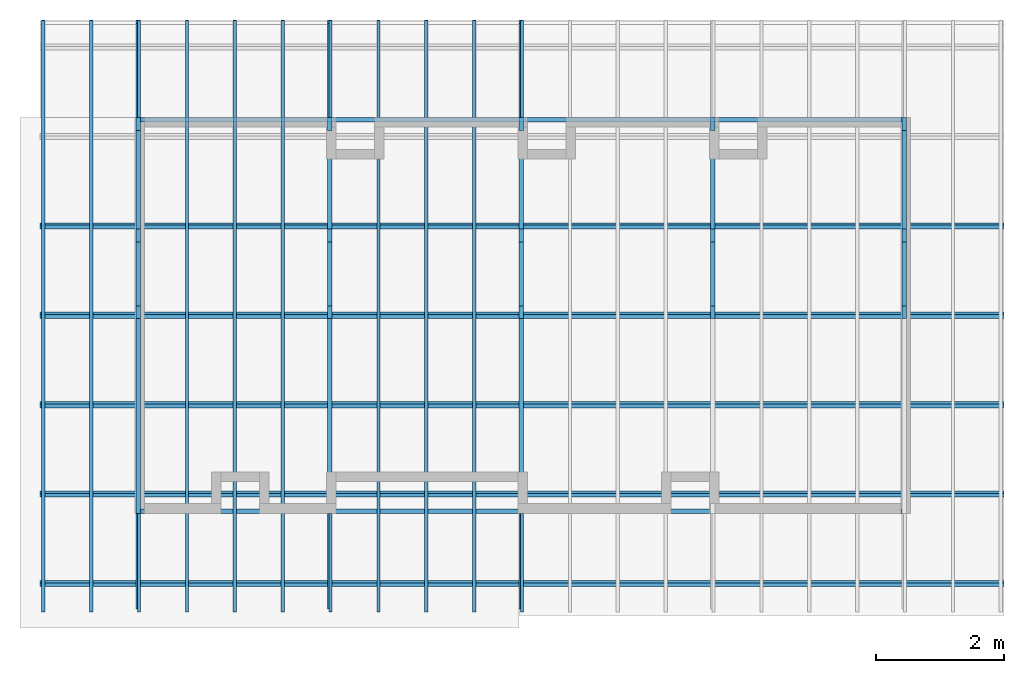
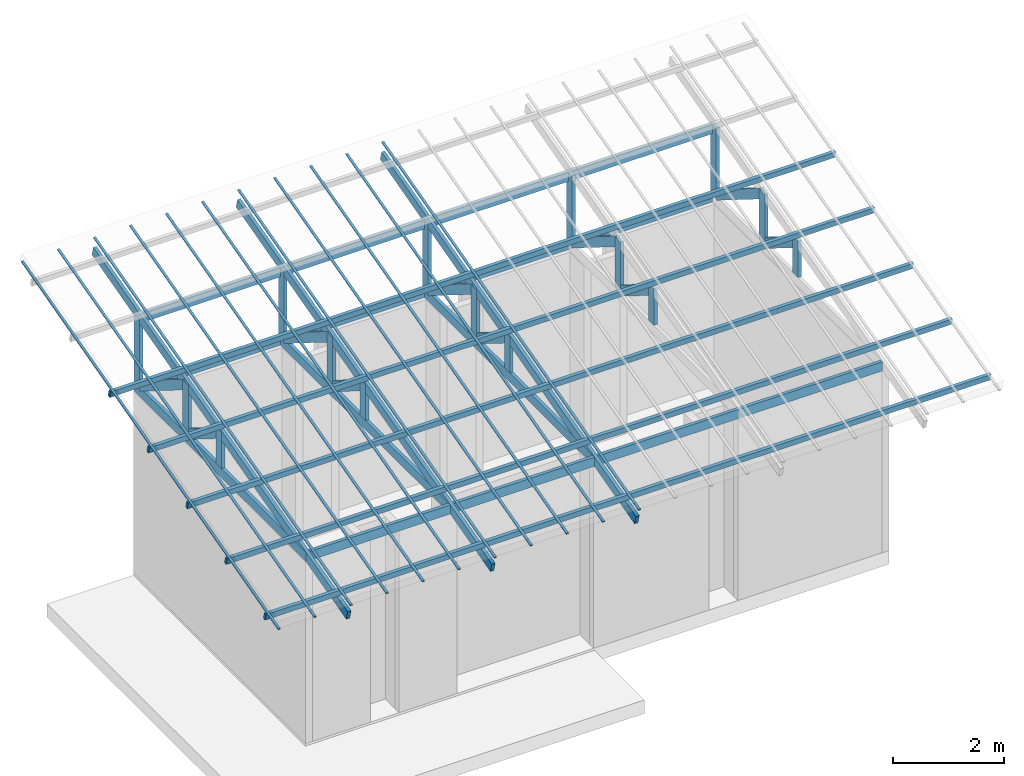
# One storey, part 1 of 4: 25 beams, 25 columns.
"""IFC4 building model written with IfcOpenShell, lengths in metres."""

from ifc_helpers import new_model, entity, si_unit, converted_unit, frame, origin_with_axes, origin_2d_with_axis, place, context, subcontext, project, spatial, rectangle, extrude, material, material_profile, profile_set, profile_usage, type_object, element, save


model = new_model("IFC4")

# Units and contexts
model_context = context("Model", 3, precision=1e-05, world=origin_with_axes())
plan_context = context("Plan", 2, precision=1e-05, world=origin_2d_with_axis())
body_context = subcontext(model_context, "Body", "Model", "MODEL_VIEW")
ifc_project = project(units=[si_unit("VOLUMEUNIT", "CUBIC_METRE"), si_unit("LENGTHUNIT", "METRE"), converted_unit("PLANEANGLEUNIT", "degree", entity("IfcReal", 0.0174532925199433), si_unit("PLANEANGLEUNIT", "RADIAN"), dimensions=[0, 0, 0, 0, 0, 0, 0]), si_unit("AREAUNIT", "SQUARE_METRE")], contexts=[model_context, plan_context])

# Site, building, storey
site_placement = place(None, origin_with_axes())
site = spatial("IfcSite", under=ifc_project, at=site_placement)
building_placement = place(site_placement, origin_with_axes())
building = spatial("IfcBuilding", under=site, at=building_placement, Name="Building")
storey_placement = place(building_placement, origin_with_axes())
storey = spatial("IfcBuildingStorey", under=building, at=storey_placement, Name="Storey")

# Columns
ifc_material = material()
ifc_material_profile_1 = material_profile(ifc_material, rectangle(XDim=0.0700000002980232, YDim=0.200000002980232))
ifc_profile_set_1 = profile_set([ifc_material_profile_1])
ifc_profile_usage_1 = profile_usage(ifc_profile_set_1, cardinal=2)
column_type = type_object("IfcColumnType", PredefinedType="COLUMN", material=ifc_profile_set_1)
column_1_placement = place(storey_placement, frame((0.0500015467405319, 6.19999980926514, 4.20000076293945), z_axis=(0.0, 0.0, 1.0), x_axis=(-1.0, -1.50995802528087e-07, 0.0)))
element("IfcColumn", 1, at=column_1_placement, inside=storey, type_object=column_type, material=ifc_profile_usage_1, Name="Column", PredefinedType="NOTDEFINED", context=body_context, shape_type="SweptSolid", body=[
    extrude(rectangle(XDim=0.0700000002980232, YDim=0.200000002980232), frame((0.0, 0.100000001490116, 0.0), z_axis=(0.0, 0.0, 1.0), x_axis=(1.0, 0.0, 0.0)), (0.0, 0.0, 1.0), 1.5),
])
ifc_profile_usage_2 = profile_usage(ifc_profile_set_1, cardinal=2)
column_2_placement = place(storey_placement, frame((0.0500015467405319, 4.44999980926514, 4.20000076293945), z_axis=(0.0, 0.0, 1.0), x_axis=(-1.0, -1.50995802528087e-07, 0.0)))
element("IfcColumn", 2, at=column_2_placement, inside=storey, type_object=column_type, material=ifc_profile_usage_2, Name="Column", PredefinedType="NOTDEFINED", context=body_context, shape_type="SweptSolid", body=[
    extrude(rectangle(XDim=0.0700000002980232, YDim=0.200000002980232), frame((0.0, 0.100000001490116, 0.0), z_axis=(0.0, 0.0, 1.0), x_axis=(1.0, 0.0, 0.0)), (0.0, 0.0, 1.0), 1.09999990896745),
])
ifc_profile_usage_3 = profile_usage(ifc_profile_set_1, cardinal=2)
column_3_placement = place(storey_placement, frame((0.0500015467405319, 3.24999976158142, 4.20000076293945), z_axis=(0.0, 0.0, 1.0), x_axis=(-1.0, -1.50995802528087e-07, 0.0)))
element("IfcColumn", 3, at=column_3_placement, inside=storey, type_object=column_type, material=ifc_profile_usage_3, Name="Column", PredefinedType="NOTDEFINED", context=body_context, shape_type="SweptSolid", body=[
    extrude(rectangle(XDim=0.0700000002980232, YDim=0.200000002980232), frame((0.0, 0.100000001490116, 0.0), z_axis=(0.0, 0.0, 1.0), x_axis=(1.0, 0.0, 0.0)), (0.0, 0.0, 1.0), 0.800000177323799),
])
ifc_profile_usage_4 = profile_usage(ifc_profile_set_1, cardinal=5)
column_4_placement = place(storey_placement, frame((0.0500014126300812, 6.04999971389771, 4.20000076293945), z_axis=(6.01946368306017e-08, -0.848048090934753, 0.529919266700745), x_axis=(-1.0, -1.50995802528087e-07, -1.28051695469367e-07)))
element("IfcColumn", 4, at=column_4_placement, inside=storey, type_object=column_type, material=ifc_profile_usage_4, Name="Column", PredefinedType="NOTDEFINED", context=body_context, shape_type="SweptSolid", body=[
    extrude(rectangle(XDim=0.0700000002980232, YDim=0.200000002980232), origin_with_axes(), (0.0, 0.0, 1.0), 1.9999996423721),
])
ifc_profile_usage_5 = profile_usage(ifc_profile_set_1, cardinal=5)
column_5_placement = place(storey_placement, frame((0.0500014536082745, 4.29999971389771, 4.20000076293945), z_axis=(6.01946368306017e-08, -0.848048090934753, 0.529919266700745), x_axis=(-1.0, -1.50995802528087e-07, -1.28051695469367e-07)))
element("IfcColumn", 5, at=column_5_placement, inside=storey, type_object=column_type, material=ifc_profile_usage_5, Name="Column", PredefinedType="NOTDEFINED", context=body_context, shape_type="SweptSolid", body=[
    extrude(rectangle(XDim=0.0700000002980232, YDim=0.200000002980232), origin_with_axes(), (0.0, 0.0, 1.0), 1.30000005639517),
])
ifc_profile_usage_6 = profile_usage(ifc_profile_set_1, cardinal=2)
column_6_placement = place(storey_placement, frame((3.05000162124634, 6.19999980926514, 4.20000076293945), z_axis=(0.0, 0.0, 1.0), x_axis=(-1.0, -1.50995802528087e-07, 0.0)))
element("IfcColumn", 6, at=column_6_placement, inside=storey, type_object=column_type, material=ifc_profile_usage_6, Name="Column", PredefinedType="NOTDEFINED", context=body_context, shape_type="SweptSolid", body=[
    extrude(rectangle(XDim=0.0700000002980232, YDim=0.200000002980232), frame((0.0, 0.100000001490116, 0.0), z_axis=(0.0, 0.0, 1.0), x_axis=(1.0, 0.0, 0.0)), (0.0, 0.0, 1.0), 1.5),
])
ifc_profile_usage_7 = profile_usage(ifc_profile_set_1, cardinal=2)
column_7_placement = place(storey_placement, frame((6.05000162124634, 6.19999980926514, 4.20000076293945), z_axis=(0.0, 0.0, 1.0), x_axis=(-1.0, -1.50995802528087e-07, 0.0)))
element("IfcColumn", 7, at=column_7_placement, inside=storey, type_object=column_type, material=ifc_profile_usage_7, Name="Column", PredefinedType="NOTDEFINED", context=body_context, shape_type="SweptSolid", body=[
    extrude(rectangle(XDim=0.0700000002980232, YDim=0.200000002980232), frame((0.0, 0.100000001490116, 0.0), z_axis=(0.0, 0.0, 1.0), x_axis=(1.0, 0.0, 0.0)), (0.0, 0.0, 1.0), 1.5),
])
ifc_profile_usage_8 = profile_usage(ifc_profile_set_1, cardinal=2)
column_8_placement = place(storey_placement, frame((9.05000114440918, 6.19999980926514, 4.20000076293945), z_axis=(0.0, 0.0, 1.0), x_axis=(-1.0, -1.50995802528087e-07, 0.0)))
element("IfcColumn", 8, at=column_8_placement, inside=storey, type_object=column_type, material=ifc_profile_usage_8, Name="Column", PredefinedType="NOTDEFINED", context=body_context, shape_type="SweptSolid", body=[
    extrude(rectangle(XDim=0.0700000002980232, YDim=0.200000002980232), frame((0.0, 0.100000001490116, 0.0), z_axis=(0.0, 0.0, 1.0), x_axis=(1.0, 0.0, 0.0)), (0.0, 0.0, 1.0), 1.5),
])
ifc_profile_usage_9 = profile_usage(ifc_profile_set_1, cardinal=2)
column_9_placement = place(storey_placement, frame((12.0500011444092, 6.19999980926514, 4.20000076293945), z_axis=(0.0, 0.0, 1.0), x_axis=(-1.0, -1.50995802528087e-07, 0.0)))
element("IfcColumn", 9, at=column_9_placement, inside=storey, type_object=column_type, material=ifc_profile_usage_9, Name="Column", PredefinedType="NOTDEFINED", context=body_context, shape_type="SweptSolid", body=[
    extrude(rectangle(XDim=0.0700000002980232, YDim=0.200000002980232), frame((0.0, 0.100000001490116, 0.0), z_axis=(0.0, 0.0, 1.0), x_axis=(1.0, 0.0, 0.0)), (0.0, 0.0, 1.0), 1.5),
])
ifc_profile_usage_10 = profile_usage(ifc_profile_set_1, cardinal=5)
column_10_placement = place(storey_placement, frame((3.05000138282776, 6.04999971389771, 4.20000076293945), z_axis=(6.01946368306017e-08, -0.848048150539398, 0.529919147491455), x_axis=(-1.0, -1.50995802528087e-07, -1.28051738101931e-07)))
element("IfcColumn", 10, at=column_10_placement, inside=storey, type_object=column_type, material=ifc_profile_usage_10, Name="Column", PredefinedType="NOTDEFINED", context=body_context, shape_type="SweptSolid", body=[
    extrude(rectangle(XDim=0.0700000002980232, YDim=0.200000002980232), origin_with_axes(), (0.0, 0.0, 1.0), 1.99999982118607),
])
ifc_profile_usage_11 = profile_usage(ifc_profile_set_1, cardinal=5)
column_11_placement = place(storey_placement, frame((6.05000162124634, 6.04999971389771, 4.20000076293945), z_axis=(6.01946368306017e-08, -0.848048150539398, 0.529919147491455), x_axis=(-1.0, -1.50995802528087e-07, -1.28051738101931e-07)))
element("IfcColumn", 11, at=column_11_placement, inside=storey, type_object=column_type, material=ifc_profile_usage_11, Name="Column", PredefinedType="NOTDEFINED", context=body_context, shape_type="SweptSolid", body=[
    extrude(rectangle(XDim=0.0700000002980232, YDim=0.200000002980232), origin_with_axes(), (0.0, 0.0, 1.0), 1.99999913573246),
])
ifc_profile_usage_12 = profile_usage(ifc_profile_set_1, cardinal=5)
column_12_placement = place(storey_placement, frame((9.05000114440918, 6.04999971389771, 4.20000076293945), z_axis=(6.01946368306017e-08, -0.848048150539398, 0.529919147491455), x_axis=(-1.0, -1.50995802528087e-07, -1.28051738101931e-07)))
element("IfcColumn", 12, at=column_12_placement, inside=storey, type_object=column_type, material=ifc_profile_usage_12, Name="Column", PredefinedType="NOTDEFINED", context=body_context, shape_type="SweptSolid", body=[
    extrude(rectangle(XDim=0.0700000002980232, YDim=0.200000002980232), origin_with_axes(), (0.0, 0.0, 1.0), 1.99999913573246),
])
ifc_profile_usage_13 = profile_usage(ifc_profile_set_1, cardinal=5)
column_13_placement = place(storey_placement, frame((12.0500011444092, 6.04999971389771, 4.20000076293945), z_axis=(6.01946368306017e-08, -0.848048150539398, 0.529919147491455), x_axis=(-1.0, -1.50995802528087e-07, -1.28051738101931e-07)))
element("IfcColumn", 13, at=column_13_placement, inside=storey, type_object=column_type, material=ifc_profile_usage_13, Name="Column", PredefinedType="NOTDEFINED", context=body_context, shape_type="SweptSolid", body=[
    extrude(rectangle(XDim=0.0700000002980232, YDim=0.200000002980232), origin_with_axes(), (0.0, 0.0, 1.0), 1.99999913573246),
])
ifc_profile_usage_14 = profile_usage(ifc_profile_set_1, cardinal=2)
column_14_placement = place(storey_placement, frame((3.05000162124634, 4.44999980926514, 4.20000076293945), z_axis=(0.0, 0.0, 1.0), x_axis=(-1.0, -1.50995802528087e-07, 0.0)))
element("IfcColumn", 14, at=column_14_placement, inside=storey, type_object=column_type, material=ifc_profile_usage_14, Name="Column", PredefinedType="NOTDEFINED", context=body_context, shape_type="SweptSolid", body=[
    extrude(rectangle(XDim=0.0700000002980232, YDim=0.200000002980232), frame((0.0, 0.100000001490116, 0.0), z_axis=(0.0, 0.0, 1.0), x_axis=(1.0, 0.0, 0.0)), (0.0, 0.0, 1.0), 1.09999990896745),
])
ifc_profile_usage_15 = profile_usage(ifc_profile_set_1, cardinal=2)
column_15_placement = place(storey_placement, frame((6.05000162124634, 4.44999980926514, 4.20000076293945), z_axis=(0.0, 0.0, 1.0), x_axis=(-1.0, -1.50995802528087e-07, 0.0)))
element("IfcColumn", 15, at=column_15_placement, inside=storey, type_object=column_type, material=ifc_profile_usage_15, Name="Column", PredefinedType="NOTDEFINED", context=body_context, shape_type="SweptSolid", body=[
    extrude(rectangle(XDim=0.0700000002980232, YDim=0.200000002980232), frame((0.0, 0.100000001490116, 0.0), z_axis=(0.0, 0.0, 1.0), x_axis=(1.0, 0.0, 0.0)), (0.0, 0.0, 1.0), 1.09999990896745),
])
ifc_profile_usage_16 = profile_usage(ifc_profile_set_1, cardinal=2)
column_16_placement = place(storey_placement, frame((9.05000114440918, 4.44999980926514, 4.20000076293945), z_axis=(0.0, 0.0, 1.0), x_axis=(-1.0, -1.50995802528087e-07, 0.0)))
element("IfcColumn", 16, at=column_16_placement, inside=storey, type_object=column_type, material=ifc_profile_usage_16, Name="Column", PredefinedType="NOTDEFINED", context=body_context, shape_type="SweptSolid", body=[
    extrude(rectangle(XDim=0.0700000002980232, YDim=0.200000002980232), frame((0.0, 0.100000001490116, 0.0), z_axis=(0.0, 0.0, 1.0), x_axis=(1.0, 0.0, 0.0)), (0.0, 0.0, 1.0), 1.09999990896745),
])
ifc_profile_usage_17 = profile_usage(ifc_profile_set_1, cardinal=2)
column_17_placement = place(storey_placement, frame((12.0500011444092, 4.44999980926514, 4.20000076293945), z_axis=(0.0, 0.0, 1.0), x_axis=(-1.0, -1.50995802528087e-07, 0.0)))
element("IfcColumn", 17, at=column_17_placement, inside=storey, type_object=column_type, material=ifc_profile_usage_17, Name="Column", PredefinedType="NOTDEFINED", context=body_context, shape_type="SweptSolid", body=[
    extrude(rectangle(XDim=0.0700000002980232, YDim=0.200000002980232), frame((0.0, 0.100000001490116, 0.0), z_axis=(0.0, 0.0, 1.0), x_axis=(1.0, 0.0, 0.0)), (0.0, 0.0, 1.0), 1.09999990896745),
])
ifc_profile_usage_18 = profile_usage(ifc_profile_set_1, cardinal=5)
column_18_placement = place(storey_placement, frame((3.05000138282776, 4.29999971389771, 4.20000076293945), z_axis=(6.01946368306017e-08, -0.848048150539398, 0.529919147491455), x_axis=(-1.0, -1.50995802528087e-07, -1.28051738101931e-07)))
element("IfcColumn", 18, at=column_18_placement, inside=storey, type_object=column_type, material=ifc_profile_usage_18, Name="Column", PredefinedType="NOTDEFINED", context=body_context, shape_type="SweptSolid", body=[
    extrude(rectangle(XDim=0.0700000002980232, YDim=0.200000002980232), origin_with_axes(), (0.0, 0.0, 1.0), 1.30000005639516),
])
ifc_profile_usage_19 = profile_usage(ifc_profile_set_1, cardinal=5)
column_19_placement = place(storey_placement, frame((6.05000162124634, 4.29999971389771, 4.20000076293945), z_axis=(6.01946368306017e-08, -0.848048150539398, 0.529919147491455), x_axis=(-1.0, -1.50995802528087e-07, -1.28051738101931e-07)))
element("IfcColumn", 19, at=column_19_placement, inside=storey, type_object=column_type, material=ifc_profile_usage_19, Name="Column", PredefinedType="NOTDEFINED", context=body_context, shape_type="SweptSolid", body=[
    extrude(rectangle(XDim=0.0700000002980232, YDim=0.200000002980232), origin_with_axes(), (0.0, 0.0, 1.0), 1.30000005639516),
])
ifc_profile_usage_20 = profile_usage(ifc_profile_set_1, cardinal=5)
column_20_placement = place(storey_placement, frame((9.05000114440918, 4.29999971389771, 4.20000076293945), z_axis=(6.01946368306017e-08, -0.848048150539398, 0.529919147491455), x_axis=(-1.0, -1.50995802528087e-07, -1.28051738101931e-07)))
element("IfcColumn", 20, at=column_20_placement, inside=storey, type_object=column_type, material=ifc_profile_usage_20, Name="Column", PredefinedType="NOTDEFINED", context=body_context, shape_type="SweptSolid", body=[
    extrude(rectangle(XDim=0.0700000002980232, YDim=0.200000002980232), origin_with_axes(), (0.0, 0.0, 1.0), 1.30000005639516),
])
ifc_profile_usage_21 = profile_usage(ifc_profile_set_1, cardinal=5)
column_21_placement = place(storey_placement, frame((12.0500011444092, 4.29999971389771, 4.20000076293945), z_axis=(6.01946368306017e-08, -0.848048150539398, 0.529919147491455), x_axis=(-1.0, -1.50995802528087e-07, -1.28051738101931e-07)))
element("IfcColumn", 21, at=column_21_placement, inside=storey, type_object=column_type, material=ifc_profile_usage_21, Name="Column", PredefinedType="NOTDEFINED", context=body_context, shape_type="SweptSolid", body=[
    extrude(rectangle(XDim=0.0700000002980232, YDim=0.200000002980232), origin_with_axes(), (0.0, 0.0, 1.0), 1.30000005639516),
])
ifc_profile_usage_22 = profile_usage(ifc_profile_set_1, cardinal=2)
column_22_placement = place(storey_placement, frame((3.05000162124634, 3.24999976158142, 4.20000076293945), z_axis=(0.0, 0.0, 1.0), x_axis=(-1.0, -1.50995802528087e-07, 0.0)))
element("IfcColumn", 22, at=column_22_placement, inside=storey, type_object=column_type, material=ifc_profile_usage_22, Name="Column", PredefinedType="NOTDEFINED", context=body_context, shape_type="SweptSolid", body=[
    extrude(rectangle(XDim=0.0700000002980232, YDim=0.200000002980232), frame((0.0, 0.100000001490116, 0.0), z_axis=(0.0, 0.0, 1.0), x_axis=(1.0, 0.0, 0.0)), (0.0, 0.0, 1.0), 0.800000177323799),
])
ifc_profile_usage_23 = profile_usage(ifc_profile_set_1, cardinal=2)
column_23_placement = place(storey_placement, frame((6.05000162124634, 3.24999976158142, 4.20000076293945), z_axis=(0.0, 0.0, 1.0), x_axis=(-1.0, -1.50995802528087e-07, 0.0)))
element("IfcColumn", 23, at=column_23_placement, inside=storey, type_object=column_type, material=ifc_profile_usage_23, Name="Column", PredefinedType="NOTDEFINED", context=body_context, shape_type="SweptSolid", body=[
    extrude(rectangle(XDim=0.0700000002980232, YDim=0.200000002980232), frame((0.0, 0.100000001490116, 0.0), z_axis=(0.0, 0.0, 1.0), x_axis=(1.0, 0.0, 0.0)), (0.0, 0.0, 1.0), 0.800000177323799),
])
ifc_profile_usage_24 = profile_usage(ifc_profile_set_1, cardinal=2)
column_24_placement = place(storey_placement, frame((9.05000114440918, 3.24999976158142, 4.20000076293945), z_axis=(0.0, 0.0, 1.0), x_axis=(-1.0, -1.50995802528087e-07, 0.0)))
element("IfcColumn", 24, at=column_24_placement, inside=storey, type_object=column_type, material=ifc_profile_usage_24, Name="Column", PredefinedType="NOTDEFINED", context=body_context, shape_type="SweptSolid", body=[
    extrude(rectangle(XDim=0.0700000002980232, YDim=0.200000002980232), frame((0.0, 0.100000001490116, 0.0), z_axis=(0.0, 0.0, 1.0), x_axis=(1.0, 0.0, 0.0)), (0.0, 0.0, 1.0), 0.800000177323799),
])
ifc_profile_usage_25 = profile_usage(ifc_profile_set_1, cardinal=2)
column_25_placement = place(storey_placement, frame((12.0500011444092, 3.24999976158142, 4.20000076293945), z_axis=(0.0, 0.0, 1.0), x_axis=(-1.0, -1.50995802528087e-07, 0.0)))
element("IfcColumn", 25, at=column_25_placement, inside=storey, type_object=column_type, material=ifc_profile_usage_25, Name="Column", PredefinedType="NOTDEFINED", context=body_context, shape_type="SweptSolid", body=[
    extrude(rectangle(XDim=0.0700000002980232, YDim=0.200000002980232), frame((0.0, 0.100000001490116, 0.0), z_axis=(0.0, 0.0, 1.0), x_axis=(1.0, 0.0, 0.0)), (0.0, 0.0, 1.0), 0.800000177323799),
])

# Beams
ifc_material_profile_2 = material_profile(ifc_material, rectangle(XDim=0.0700000002980232, YDim=0.200000002980232))
ifc_profile_set_2 = profile_set([ifc_material_profile_2])
ifc_profile_usage_26 = profile_usage(ifc_profile_set_2, cardinal=2)
beam_type_1 = type_object("IfcBeamType", PredefinedType="BEAM", material=ifc_profile_set_2)
beam_1_placement = place(storey_placement, frame((0.0500015541911125, 6.19999980926514, 4.00000095367432), z_axis=(-1.19209303761636e-07, -1.0, -1.62920684942947e-07), x_axis=(1.0, -1.19209317972491e-07, 4.3711398944879e-08)))
element("IfcBeam", 26, at=beam_1_placement, inside=storey, type_object=beam_type_1, material=ifc_profile_usage_26, Name="Beam", PredefinedType="NOTDEFINED", context=body_context, shape_type="SweptSolid", body=[
    extrude(rectangle(XDim=0.0700000002980232, YDim=0.200000002980232), frame((0.0, 0.100000001490116, 0.0), z_axis=(0.0, 0.0, 1.0), x_axis=(1.0, 0.0, 0.0)), (0.0, 0.0, 1.0), 6.19999988925084),
])
ifc_profile_usage_27 = profile_usage(ifc_profile_set_2, cardinal=2)
beam_2_placement = place(storey_placement, frame((3.05000162124634, 6.19999980926514, 4.00000095367432), z_axis=(-1.19209303761636e-07, -1.0, -1.62920684942947e-07), x_axis=(1.0, -1.19209317972491e-07, 4.37113918394516e-08)))
element("IfcBeam", 27, at=beam_2_placement, inside=storey, type_object=beam_type_1, material=ifc_profile_usage_27, Name="Beam", PredefinedType="NOTDEFINED", context=body_context, shape_type="SweptSolid", body=[
    extrude(rectangle(XDim=0.0700000002980232, YDim=0.200000002980232), frame((0.0, 0.100000001490116, 0.0), z_axis=(0.0, 0.0, 1.0), x_axis=(1.0, 0.0, 0.0)), (0.0, 0.0, 1.0), 6.19999988925084),
])
ifc_profile_usage_28 = profile_usage(ifc_profile_set_2, cardinal=2)
beam_3_placement = place(storey_placement, frame((6.05000162124634, 6.19999980926514, 4.00000095367432), z_axis=(-1.19209303761636e-07, -1.0, -1.62920684942947e-07), x_axis=(1.0, -1.19209317972491e-07, 4.37113918394516e-08)))
element("IfcBeam", 28, at=beam_3_placement, inside=storey, type_object=beam_type_1, material=ifc_profile_usage_28, Name="Beam", PredefinedType="NOTDEFINED", context=body_context, shape_type="SweptSolid", body=[
    extrude(rectangle(XDim=0.0700000002980232, YDim=0.200000002980232), frame((0.0, 0.100000001490116, 0.0), z_axis=(0.0, 0.0, 1.0), x_axis=(1.0, 0.0, 0.0)), (0.0, 0.0, 1.0), 6.19999988925087),
])
ifc_profile_usage_29 = profile_usage(ifc_profile_set_2, cardinal=2)
beam_4_placement = place(storey_placement, frame((0.0500008016824722, -1.44888913631439, 3.61177134513855), z_axis=(1.66893400432855e-07, 0.965925753116608, 0.258819311857224), x_axis=(-1.0, 1.50995802528087e-07, 8.13025735624251e-08)))
element("IfcBeam", 29, at=beam_4_placement, inside=storey, type_object=beam_type_1, material=ifc_profile_usage_29, Name="Beam", PredefinedType="NOTDEFINED", context=body_context, shape_type="SweptSolid", body=[
    extrude(rectangle(XDim=0.0700000002980232, YDim=0.200000002980232), frame((0.0, 0.100000001490116, 0.0), z_axis=(0.0, 0.0, 1.0), x_axis=(1.0, 0.0, 0.0)), (0.0, 0.0, 1.0), 9.49999957335635),
])
ifc_profile_usage_30 = profile_usage(ifc_profile_set_2, cardinal=2)
beam_5_placement = place(storey_placement, frame((3.0500009059906, -1.44888913631439, 3.61177134513855), z_axis=(1.6689341464371e-07, 0.965925753116608, 0.258819311857224), x_axis=(-1.0, 1.50995802528087e-07, 8.13025877732798e-08)))
element("IfcBeam", 30, at=beam_5_placement, inside=storey, type_object=beam_type_1, material=ifc_profile_usage_30, Name="Beam", PredefinedType="NOTDEFINED", context=body_context, shape_type="SweptSolid", body=[
    extrude(rectangle(XDim=0.0700000002980232, YDim=0.200000002980232), frame((0.0, 0.100000001490116, 0.0), z_axis=(0.0, 0.0, 1.0), x_axis=(1.0, 0.0, 0.0)), (0.0, 0.0, 1.0), 9.49999957335636),
])
ifc_profile_usage_31 = profile_usage(ifc_profile_set_2, cardinal=2)
beam_6_placement = place(storey_placement, frame((6.05000066757202, -1.44888913631439, 3.61177134513855), z_axis=(1.6689341464371e-07, 0.965925753116608, 0.258819311857224), x_axis=(-1.0, 1.50995802528087e-07, 8.13025877732798e-08)))
element("IfcBeam", 31, at=beam_6_placement, inside=storey, type_object=beam_type_1, material=ifc_profile_usage_31, Name="Beam", PredefinedType="NOTDEFINED", context=body_context, shape_type="SweptSolid", body=[
    extrude(rectangle(XDim=0.0700000002980232, YDim=0.200000002980232), frame((0.0, 0.100000001490116, 0.0), z_axis=(0.0, 0.0, 1.0), x_axis=(1.0, 0.0, 0.0)), (0.0, 0.0, 1.0), 9.49999957335632),
])
ifc_profile_usage_32 = profile_usage(ifc_profile_set_2, cardinal=2)
beam_7_placement = place(storey_placement, frame((12.0150012969971, 0.0350008644163609, 4.0), z_axis=(-1.0, 4.37113882867379e-08, -4.37113882867379e-08), x_axis=(-4.37113882867379e-08, -1.0, 5.96046376699633e-08)))
element("IfcBeam", 32, at=beam_7_placement, inside=storey, type_object=beam_type_1, material=ifc_profile_usage_32, Name="Beam", PredefinedType="NOTDEFINED", context=body_context, shape_type="SweptSolid", body=[
    extrude(rectangle(XDim=0.0700000002980232, YDim=0.200000002980232), frame((0.0, 0.100000001490116, 0.0), z_axis=(0.0, 0.0, 1.0), x_axis=(1.0, 0.0, 0.0)), (0.0, 0.0, 1.0), 11.9300002261319),
])
ifc_profile_usage_33 = profile_usage(ifc_profile_set_2, cardinal=2)
beam_8_placement = place(storey_placement, frame((0.0850015878677368, 6.16499996185303, 4.00000095367432), z_axis=(1.0, 1.62920699153801e-07, -1.62920684942947e-07), x_axis=(-1.62920684942947e-07, 1.0, 1.19209275339927e-07)))
element("IfcBeam", 33, at=beam_8_placement, inside=storey, type_object=beam_type_1, material=ifc_profile_usage_33, Name="Beam", PredefinedType="NOTDEFINED", context=body_context, shape_type="SweptSolid", body=[
    extrude(rectangle(XDim=0.0700000002980232, YDim=0.200000002980232), frame((0.0, 0.100000001490116, 0.0), z_axis=(0.0, 0.0, 1.0), x_axis=(1.0, 0.0, 0.0)), (0.0, 0.0, 1.0), 11.9299995866189),
])
ifc_profile_usage_34 = profile_usage(ifc_profile_set_2, cardinal=2)
beam_9_placement = place(storey_placement, frame((0.0150025263428688, 6.16499996185303, 5.50000095367432), z_axis=(1.0, 1.62920699153801e-07, -1.62920684942947e-07), x_axis=(-1.62920684942947e-07, 1.0, 1.19209275339927e-07)))
element("IfcBeam", 34, at=beam_9_placement, inside=storey, type_object=beam_type_1, material=ifc_profile_usage_34, Name="Beam", PredefinedType="NOTDEFINED", context=body_context, shape_type="SweptSolid", body=[
    extrude(rectangle(XDim=0.0700000002980232, YDim=0.200000002980232), frame((0.0, 0.100000001490116, 0.0), z_axis=(0.0, 0.0, 1.0), x_axis=(1.0, 0.0, 0.0)), (0.0, 0.0, 1.0), 12.0699996166975),
])
ifc_material_profile_3 = material_profile(ifc_material, rectangle(XDim=0.0599999986588955, YDim=0.150000005960464))
ifc_profile_set_3 = profile_set([ifc_material_profile_3])
ifc_profile_usage_35 = profile_usage(ifc_profile_set_3, cardinal=2)
beam_type_2 = type_object("IfcBeamType", Name="Caibro", PredefinedType="BEAM", material=ifc_profile_set_3)
beam_10_placement = place(storey_placement, frame((-1.48499929904938, -1.08047533035278, 3.9175431728363), z_axis=(1.0, 2.05087800964066e-07, -1.57369257181017e-07), x_axis=(-1.57369242970162e-07, 0.965925514698029, 0.258819878101349)))
element("IfcBeam", 35, at=beam_10_placement, inside=storey, type_object=beam_type_2, material=ifc_profile_usage_35, Name="Beam", PredefinedType="NOTDEFINED", context=body_context, shape_type="SweptSolid", body=[
    extrude(rectangle(XDim=0.0599999986588955, YDim=0.150000005960464), frame((0.0, 0.075000002980232, 0.0), z_axis=(0.0, 0.0, 1.0), x_axis=(1.0, 0.0, 0.0)), (0.0, 0.0, 1.0), 15.1000003233656),
])
ifc_profile_usage_36 = profile_usage(ifc_profile_set_3, cardinal=2)
beam_11_placement = place(storey_placement, frame((-1.48499953746796, 0.320116758346558, 4.2928318977356), z_axis=(1.0, 1.74234060068557e-07, -4.22219486040376e-08), x_axis=(-1.57369242970162e-07, 0.965925514698029, 0.258819907903671)))
element("IfcBeam", 36, at=beam_11_placement, inside=storey, type_object=beam_type_2, material=ifc_profile_usage_36, Name="Beam", PredefinedType="NOTDEFINED", context=body_context, shape_type="SweptSolid", body=[
    extrude(rectangle(XDim=0.0599999986588955, YDim=0.150000005960464), frame((0.0, 0.075000002980232, 0.0), z_axis=(0.0, 0.0, 1.0), x_axis=(1.0, 0.0, 0.0)), (0.0, 0.0, 1.0), 15.1000003233656),
])
ifc_profile_usage_37 = profile_usage(ifc_profile_set_3, cardinal=2)
beam_12_placement = place(storey_placement, frame((-1.48499977588654, 1.7207088470459, 4.66812086105347), z_axis=(1.0, 1.74234060068557e-07, -4.22219486040376e-08), x_axis=(-1.57369242970162e-07, 0.965925514698029, 0.258819907903671)))
element("IfcBeam", 37, at=beam_12_placement, inside=storey, type_object=beam_type_2, material=ifc_profile_usage_37, Name="Beam", PredefinedType="NOTDEFINED", context=body_context, shape_type="SweptSolid", body=[
    extrude(rectangle(XDim=0.0599999986588955, YDim=0.150000005960464), frame((0.0, 0.075000002980232, 0.0), z_axis=(0.0, 0.0, 1.0), x_axis=(1.0, 0.0, 0.0)), (0.0, 0.0, 1.0), 15.1000003233656),
])
ifc_profile_usage_38 = profile_usage(ifc_profile_set_3, cardinal=2)
beam_13_placement = place(storey_placement, frame((-1.48500001430511, 3.12130117416382, 5.04340982437134), z_axis=(1.0, 1.74234060068557e-07, -4.22219486040376e-08), x_axis=(-1.57369242970162e-07, 0.965925514698029, 0.258819907903671)))
element("IfcBeam", 38, at=beam_13_placement, inside=storey, type_object=beam_type_2, material=ifc_profile_usage_38, Name="Beam", PredefinedType="NOTDEFINED", context=body_context, shape_type="SweptSolid", body=[
    extrude(rectangle(XDim=0.0599999986588955, YDim=0.150000005960464), frame((0.0, 0.075000002980232, 0.0), z_axis=(0.0, 0.0, 1.0), x_axis=(1.0, 0.0, 0.0)), (0.0, 0.0, 1.0), 15.1000003233656),
])
ifc_profile_usage_39 = profile_usage(ifc_profile_set_3, cardinal=2)
beam_14_placement = place(storey_placement, frame((-1.48500025272369, 4.52189302444458, 5.41869831085205), z_axis=(1.0, 1.74234060068557e-07, -4.22219486040376e-08), x_axis=(-1.57369242970162e-07, 0.965925514698029, 0.258819907903671)))
element("IfcBeam", 39, at=beam_14_placement, inside=storey, type_object=beam_type_2, material=ifc_profile_usage_39, Name="Beam", PredefinedType="NOTDEFINED", context=body_context, shape_type="SweptSolid", body=[
    extrude(rectangle(XDim=0.0599999986588955, YDim=0.150000005960464), frame((0.0, 0.075000002980232, 0.0), z_axis=(0.0, 0.0, 1.0), x_axis=(1.0, 0.0, 0.0)), (0.0, 0.0, 1.0), 15.1000003233656),
])
ifc_material_profile_4 = material_profile(ifc_material, rectangle(XDim=0.0500000007450581, YDim=0.0199999995529652))
ifc_profile_set_4 = profile_set([ifc_material_profile_4])
ifc_profile_usage_40 = profile_usage(ifc_profile_set_4, cardinal=2)
beam_type_3 = type_object("IfcBeamType", PredefinedType="BEAM", material=ifc_profile_set_4)
beam_15_placement = place(storey_placement, frame((-1.43500006198883, -1.53888702392578, 3.95000076293945), z_axis=(-9.95067125586502e-07, 0.965925514698029, 0.258820205926895), x_axis=(-1.0, -1.04109710719058e-06, 4.07814688685448e-08)))
element("IfcBeam", 40, at=beam_15_placement, inside=storey, type_object=beam_type_3, material=ifc_profile_usage_40, Name="Beam", PredefinedType="NOTDEFINED", context=body_context, shape_type="SweptSolid", body=[
    extrude(rectangle(XDim=0.0500000007450581, YDim=0.0199999995529652), frame((0.0, 0.0099999997764826, 0.0), z_axis=(0.0, 0.0, 1.0), x_axis=(1.0, 0.0, 0.0)), (0.0, 0.0, 1.0), 9.5898903404752),
])
ifc_profile_usage_41 = profile_usage(ifc_profile_set_4, cardinal=2)
beam_16_placement = place(storey_placement, frame((-0.685000061988831, -1.53888702392578, 3.95000076293945), z_axis=(-1.05647404780029e-06, 0.965925574302673, 0.258819997310638), x_axis=(-1.0, -1.10467010472348e-06, 4.078152215925e-08)))
element("IfcBeam", 41, at=beam_16_placement, inside=storey, type_object=beam_type_3, material=ifc_profile_usage_41, Name="Beam", PredefinedType="NOTDEFINED", context=body_context, shape_type="SweptSolid", body=[
    extrude(rectangle(XDim=0.0500000007450581, YDim=0.0199999995529652), frame((0.0, 0.0099999997764826, 0.0), z_axis=(0.0, 0.0, 1.0), x_axis=(1.0, 0.0, 0.0)), (0.0, 0.0, 1.0), 9.5898903404752),
])
ifc_profile_usage_42 = profile_usage(ifc_profile_set_4, cardinal=2)
beam_17_placement = place(storey_placement, frame((0.0649999380111694, -1.53888702392578, 3.95000076293945), z_axis=(-1.05647404780029e-06, 0.965925574302673, 0.258819997310638), x_axis=(-1.0, -1.10467010472348e-06, 4.078152215925e-08)))
element("IfcBeam", 42, at=beam_17_placement, inside=storey, type_object=beam_type_3, material=ifc_profile_usage_42, Name="Beam", PredefinedType="NOTDEFINED", context=body_context, shape_type="SweptSolid", body=[
    extrude(rectangle(XDim=0.0500000007450581, YDim=0.0199999995529652), frame((0.0, 0.0099999997764826, 0.0), z_axis=(0.0, 0.0, 1.0), x_axis=(1.0, 0.0, 0.0)), (0.0, 0.0, 1.0), 9.5898903404752),
])
ifc_profile_usage_43 = profile_usage(ifc_profile_set_4, cardinal=2)
beam_18_placement = place(storey_placement, frame((0.814999938011169, -1.53888702392578, 3.95000076293945), z_axis=(-1.05647404780029e-06, 0.965925574302673, 0.258819997310638), x_axis=(-1.0, -1.10467010472348e-06, 4.078152215925e-08)))
element("IfcBeam", 43, at=beam_18_placement, inside=storey, type_object=beam_type_3, material=ifc_profile_usage_43, Name="Beam", PredefinedType="NOTDEFINED", context=body_context, shape_type="SweptSolid", body=[
    extrude(rectangle(XDim=0.0500000007450581, YDim=0.0199999995529652), frame((0.0, 0.0099999997764826, 0.0), z_axis=(0.0, 0.0, 1.0), x_axis=(1.0, 0.0, 0.0)), (0.0, 0.0, 1.0), 9.5898903404752),
])
ifc_profile_usage_44 = profile_usage(ifc_profile_set_4, cardinal=2)
beam_19_placement = place(storey_placement, frame((1.56499993801117, -1.53888702392578, 3.95000076293945), z_axis=(-1.05647404780029e-06, 0.965925574302673, 0.258819997310638), x_axis=(-1.0, -1.10467010472348e-06, 4.078152215925e-08)))
element("IfcBeam", 44, at=beam_19_placement, inside=storey, type_object=beam_type_3, material=ifc_profile_usage_44, Name="Beam", PredefinedType="NOTDEFINED", context=body_context, shape_type="SweptSolid", body=[
    extrude(rectangle(XDim=0.0500000007450581, YDim=0.0199999995529652), frame((0.0, 0.0099999997764826, 0.0), z_axis=(0.0, 0.0, 1.0), x_axis=(1.0, 0.0, 0.0)), (0.0, 0.0, 1.0), 9.5898903404752),
])
ifc_profile_usage_45 = profile_usage(ifc_profile_set_4, cardinal=2)
beam_20_placement = place(storey_placement, frame((2.31500005722046, -1.53888702392578, 3.95000076293945), z_axis=(-1.05647404780029e-06, 0.965925574302673, 0.258819997310638), x_axis=(-1.0, -1.10467010472348e-06, 4.078152215925e-08)))
element("IfcBeam", 45, at=beam_20_placement, inside=storey, type_object=beam_type_3, material=ifc_profile_usage_45, Name="Beam", PredefinedType="NOTDEFINED", context=body_context, shape_type="SweptSolid", body=[
    extrude(rectangle(XDim=0.0500000007450581, YDim=0.0199999995529652), frame((0.0, 0.0099999997764826, 0.0), z_axis=(0.0, 0.0, 1.0), x_axis=(1.0, 0.0, 0.0)), (0.0, 0.0, 1.0), 9.5898903404752),
])
ifc_profile_usage_46 = profile_usage(ifc_profile_set_4, cardinal=2)
beam_21_placement = place(storey_placement, frame((3.06500005722046, -1.53888702392578, 3.95000076293945), z_axis=(-1.05647404780029e-06, 0.965925574302673, 0.258819997310638), x_axis=(-1.0, -1.10467010472348e-06, 4.078152215925e-08)))
element("IfcBeam", 46, at=beam_21_placement, inside=storey, type_object=beam_type_3, material=ifc_profile_usage_46, Name="Beam", PredefinedType="NOTDEFINED", context=body_context, shape_type="SweptSolid", body=[
    extrude(rectangle(XDim=0.0500000007450581, YDim=0.0199999995529652), frame((0.0, 0.0099999997764826, 0.0), z_axis=(0.0, 0.0, 1.0), x_axis=(1.0, 0.0, 0.0)), (0.0, 0.0, 1.0), 9.5898903404752),
])
ifc_profile_usage_47 = profile_usage(ifc_profile_set_4, cardinal=2)
beam_22_placement = place(storey_placement, frame((3.81500005722046, -1.53888702392578, 3.95000076293945), z_axis=(-1.05647404780029e-06, 0.965925574302673, 0.258819997310638), x_axis=(-1.0, -1.10467010472348e-06, 4.078152215925e-08)))
element("IfcBeam", 47, at=beam_22_placement, inside=storey, type_object=beam_type_3, material=ifc_profile_usage_47, Name="Beam", PredefinedType="NOTDEFINED", context=body_context, shape_type="SweptSolid", body=[
    extrude(rectangle(XDim=0.0500000007450581, YDim=0.0199999995529652), frame((0.0, 0.0099999997764826, 0.0), z_axis=(0.0, 0.0, 1.0), x_axis=(1.0, 0.0, 0.0)), (0.0, 0.0, 1.0), 9.5898903404752),
])
ifc_profile_usage_48 = profile_usage(ifc_profile_set_4, cardinal=2)
beam_23_placement = place(storey_placement, frame((4.56500005722046, -1.53888702392578, 3.95000076293945), z_axis=(-1.05647404780029e-06, 0.965925574302673, 0.258819997310638), x_axis=(-1.0, -1.10467010472348e-06, 4.078152215925e-08)))
element("IfcBeam", 48, at=beam_23_placement, inside=storey, type_object=beam_type_3, material=ifc_profile_usage_48, Name="Beam", PredefinedType="NOTDEFINED", context=body_context, shape_type="SweptSolid", body=[
    extrude(rectangle(XDim=0.0500000007450581, YDim=0.0199999995529652), frame((0.0, 0.0099999997764826, 0.0), z_axis=(0.0, 0.0, 1.0), x_axis=(1.0, 0.0, 0.0)), (0.0, 0.0, 1.0), 9.5898903404752),
])
ifc_profile_usage_49 = profile_usage(ifc_profile_set_4, cardinal=2)
beam_24_placement = place(storey_placement, frame((5.31500005722046, -1.53888702392578, 3.95000076293945), z_axis=(-1.05647404780029e-06, 0.965925574302673, 0.258819997310638), x_axis=(-1.0, -1.10467010472348e-06, 4.078152215925e-08)))
element("IfcBeam", 49, at=beam_24_placement, inside=storey, type_object=beam_type_3, material=ifc_profile_usage_49, Name="Beam", PredefinedType="NOTDEFINED", context=body_context, shape_type="SweptSolid", body=[
    extrude(rectangle(XDim=0.0500000007450581, YDim=0.0199999995529652), frame((0.0, 0.0099999997764826, 0.0), z_axis=(0.0, 0.0, 1.0), x_axis=(1.0, 0.0, 0.0)), (0.0, 0.0, 1.0), 9.5898903404752),
])
ifc_profile_usage_50 = profile_usage(ifc_profile_set_4, cardinal=2)
beam_25_placement = place(storey_placement, frame((6.06500005722046, -1.53888702392578, 3.95000076293945), z_axis=(-1.05647404780029e-06, 0.965925574302673, 0.258819997310638), x_axis=(-1.0, -1.10467010472348e-06, 4.078152215925e-08)))
element("IfcBeam", 50, at=beam_25_placement, inside=storey, type_object=beam_type_3, material=ifc_profile_usage_50, Name="Beam", PredefinedType="NOTDEFINED", context=body_context, shape_type="SweptSolid", body=[
    extrude(rectangle(XDim=0.0500000007450581, YDim=0.0199999995529652), frame((0.0, 0.0099999997764826, 0.0), z_axis=(0.0, 0.0, 1.0), x_axis=(1.0, 0.0, 0.0)), (0.0, 0.0, 1.0), 9.5898903404752),
])

save(model, "model.ifc")
